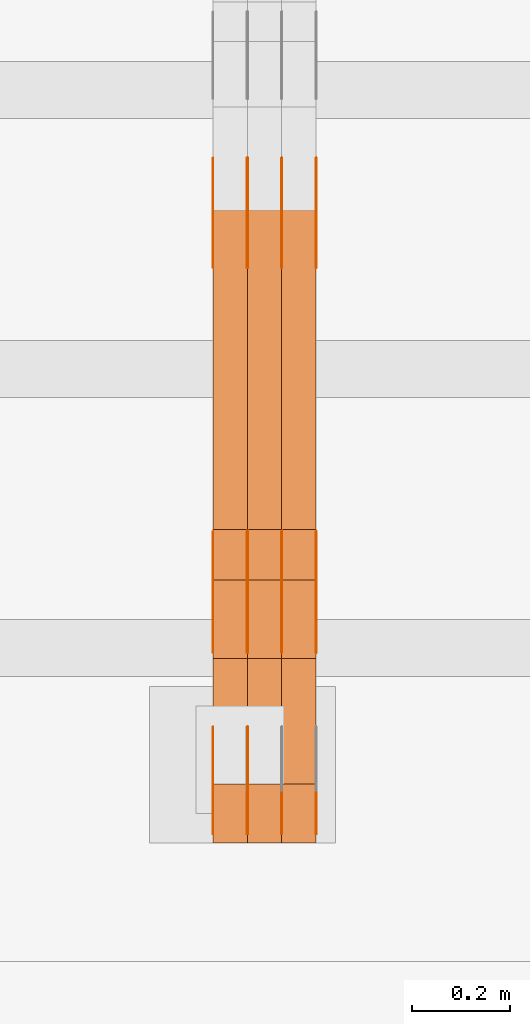
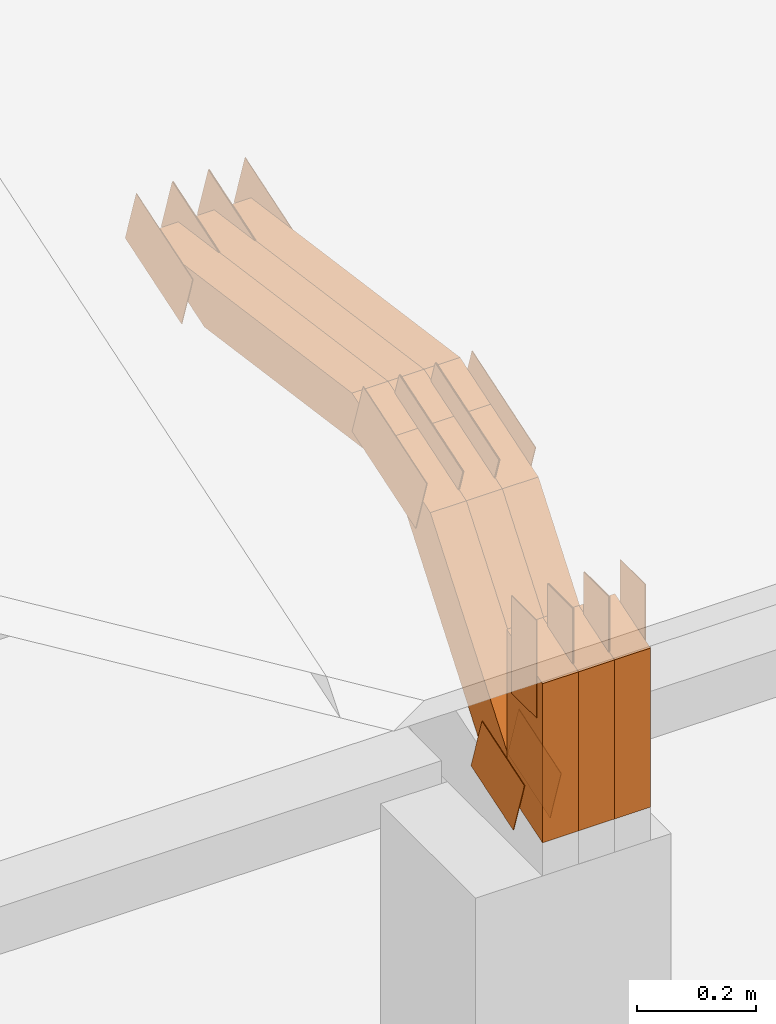
# One storey, part 57 of 385: 29 proxies.
"""IFC2X3 building model written with IfcOpenShell, lengths in millimetres."""

from ifc_helpers import new_model, entity, si_unit, converted_unit, derived_unit, direction, frame, frame_2d, origin, place, context, subcontext, project, spatial, polyline, rectangle, outline, extrude, source, transform, mapped, material, type_object, type_shapes, element, save


model = new_model("IFC2X3")

# Units and contexts
model_context = context("Model", 3, precision=0.01, world=origin(), true_north=direction((6.12303176911189e-17, 1.0)))
body_context = subcontext(model_context, "Body", "Model", "MODEL_VIEW")
ifc_project = project(units=[si_unit("LENGTHUNIT", "METRE", prefix="MILLI"), si_unit("AREAUNIT", "SQUARE_METRE"), si_unit("VOLUMEUNIT", "CUBIC_METRE"), converted_unit("PLANEANGLEUNIT", "DEGREE", entity("IfcRatioMeasure", 0.0174532925199433), si_unit("PLANEANGLEUNIT", "RADIAN"), dimensions=[0, 0, 0, 0, 0, 0, 0]), si_unit("MASSUNIT", "GRAM", prefix="KILO"), derived_unit("MASSDENSITYUNIT", [(si_unit("MASSUNIT", "GRAM", prefix="KILO"), 1), (si_unit("LENGTHUNIT", "METRE"), -3)]), si_unit("TIMEUNIT", "SECOND"), si_unit("FREQUENCYUNIT", "HERTZ"), si_unit("THERMODYNAMICTEMPERATUREUNIT", "DEGREE_CELSIUS"), derived_unit("THERMALTRANSMITTANCEUNIT", [(si_unit("MASSUNIT", "GRAM", prefix="KILO"), 1), (si_unit("THERMODYNAMICTEMPERATUREUNIT", "KELVIN"), -1), (si_unit("TIMEUNIT", "SECOND"), -3)]), derived_unit("VOLUMETRICFLOWRATEUNIT", [(si_unit("LENGTHUNIT", "METRE"), 3), (si_unit("TIMEUNIT", "SECOND"), -1)]), si_unit("ELECTRICCURRENTUNIT", "AMPERE"), si_unit("ELECTRICVOLTAGEUNIT", "VOLT"), si_unit("POWERUNIT", "WATT"), si_unit("FORCEUNIT", "NEWTON", prefix="KILO"), si_unit("ILLUMINANCEUNIT", "LUX"), si_unit("LUMINOUSFLUXUNIT", "LUMEN"), si_unit("LUMINOUSINTENSITYUNIT", "CANDELA"), derived_unit("USERDEFINED", [(si_unit("MASSUNIT", "GRAM", prefix="KILO"), -1), (si_unit("LENGTHUNIT", "METRE"), -2), (si_unit("TIMEUNIT", "SECOND"), 3), (si_unit("LUMINOUSFLUXUNIT", "LUMEN"), 1)]), derived_unit("LINEARVELOCITYUNIT", [(si_unit("LENGTHUNIT", "METRE"), 1), (si_unit("TIMEUNIT", "SECOND"), -1)]), si_unit("PRESSUREUNIT", "PASCAL"), derived_unit("USERDEFINED", [(si_unit("LENGTHUNIT", "METRE"), -2), (si_unit("MASSUNIT", "GRAM", prefix="KILO"), 1), (si_unit("TIMEUNIT", "SECOND"), -2)])], contexts=[model_context])

# Site, building, storey
site_placement = place(None, origin())
site = spatial("IfcSite", under=ifc_project, at=site_placement, CompositionType="ELEMENT")
building_placement = place(site_placement, origin())
building = spatial("IfcBuilding", under=site, at=building_placement, CompositionType="ELEMENT")
storey_placement = place(building_placement, origin())
storey = spatial("IfcBuildingStorey", under=building, at=storey_placement, Name="Default", CompositionType="ELEMENT", Elevation=0.0)

# Proxies
ifc_material_1 = material(Name="IfcSurfaceStyle #167640")
building_element_proxy_type_1 = type_object("IfcBuildingElementProxyType", PredefinedType="NOTDEFINED", material=ifc_material_1)
shared_shape_1 = source(origin(), body_context, "Body", "SweptSolid", [
    extrude(outline(polyline([(-74.999865408764, -60.0000379172698), (74.9998729365771, -60.0000379172698), (74.9998642299588, 60.0000379172698), (-74.9998717577719, 60.0000379172698), (-74.999865408764, -60.0000379172698)])), frame((75.0005044383734, 60.0001679035349, 0.0), z_axis=(0.0, 0.0, 1.0), x_axis=(-1.0, 0.0, 0.0)), (0.0, 0.0, 1.0), 1.29999999999999),
])
type_shapes(building_element_proxy_type_1, [shared_shape_1])
proxy_1_placement = place(building_placement, frame((12246.3, 2998.66143710397, 150.423871180894), z_axis=(-1.0, 0.0, 0.0), x_axis=(0.0, 0.951056516295124, 0.309016994375039)))
element("IfcBuildingElementProxy", 1, at=proxy_1_placement, inside=storey, type_object=building_element_proxy_type_1, material=ifc_material_1, context=body_context, shape_type="MappedRepresentation", body=[
    mapped(shared_shape_1, transform((0.0, 0.0, 0.0), scale=1.0)),
])
ifc_material_2 = material(Name="IfcSurfaceStyle #167583")
building_element_proxy_type_2 = type_object("IfcBuildingElementProxyType", PredefinedType="NOTDEFINED", material=ifc_material_2)
shared_shape_2 = source(origin(), body_context, "Body", "SweptSolid", [
    extrude(outline(polyline([(-74.999865408764, -60.0000379172698), (74.9998729365771, -60.0000379172698), (74.9998642299588, 60.0000379172698), (-74.9998717577719, 60.0000379172698), (-74.999865408764, -60.0000379172698)])), frame((75.0005044383734, 60.0001679035349, 0.0), z_axis=(0.0, 0.0, 1.0), x_axis=(-1.0, 0.0, 0.0)), (0.0, 0.0, 1.0), 1.29999999999999),
])
type_shapes(building_element_proxy_type_2, [shared_shape_2])
proxy_2_placement = place(building_placement, frame((12175.0, 2998.66143710397, 150.423871180894), z_axis=(-1.0, 0.0, 0.0), x_axis=(0.0, 0.951056516295124, 0.309016994375039)))
element("IfcBuildingElementProxy", 2, at=proxy_2_placement, inside=storey, type_object=building_element_proxy_type_2, material=ifc_material_2, context=body_context, shape_type="MappedRepresentation", body=[
    mapped(shared_shape_2, transform((0.0, 0.0, 0.0), scale=1.0)),
])
ifc_material_3 = material(Name="IfcSurfaceStyle #167526")
building_element_proxy_type_3 = type_object("IfcBuildingElementProxyType", PredefinedType="NOTDEFINED", material=ifc_material_3)
shared_shape_3 = source(origin(), body_context, "Body", "SweptSolid", [
    extrude(outline(polyline([(-99.9998204243802, -60.000067376167), (99.9998338462265, -60.000067376167), (99.9998204243802, 60.000067376167), (-99.9998338462265, 60.000067376167), (-99.9998204243802, -60.000067376167)])), frame((100.000602015329, 60.0001864986889, 0.0), z_axis=(0.0, 0.0, 1.0), x_axis=(-1.0, 0.0, 0.0)), (0.0, 0.0, 1.0), 1.3),
])
type_shapes(building_element_proxy_type_3, [shared_shape_3])
proxy_3_placement = place(building_placement, frame((12386.3, 4114.85465165112, 513.097031388771), z_axis=(-1.0, 0.0, 0.0), x_axis=(0.0, 0.951056516295124, 0.309016994375039)))
element("IfcBuildingElementProxy", 3, at=proxy_3_placement, inside=storey, type_object=building_element_proxy_type_3, material=ifc_material_3, context=body_context, shape_type="MappedRepresentation", body=[
    mapped(shared_shape_3, transform((0.0, 0.0, 0.0), scale=1.0)),
])
ifc_material_4 = material(Name="IfcSurfaceStyle #167469")
building_element_proxy_type_4 = type_object("IfcBuildingElementProxyType", PredefinedType="NOTDEFINED", material=ifc_material_4)
shared_shape_4 = source(origin(), body_context, "Body", "SweptSolid", [
    extrude(outline(polyline([(-99.9998204243802, -60.000067376167), (99.9998338462265, -60.000067376167), (99.9998204243802, 60.000067376167), (-99.9998338462265, 60.000067376167), (-99.9998204243802, -60.000067376167)])), frame((100.000602015329, 60.0001864986889, 0.0), z_axis=(0.0, 0.0, 1.0), x_axis=(-1.0, 0.0, 0.0)), (0.0, 0.0, 1.0), 1.3),
])
type_shapes(building_element_proxy_type_4, [shared_shape_4])
proxy_4_placement = place(building_placement, frame((12315.0, 4114.85465165112, 513.097031388771), z_axis=(-1.0, 0.0, 0.0), x_axis=(0.0, 0.951056516295124, 0.309016994375039)))
element("IfcBuildingElementProxy", 4, at=proxy_4_placement, inside=storey, type_object=building_element_proxy_type_4, material=ifc_material_4, context=body_context, shape_type="MappedRepresentation", body=[
    mapped(shared_shape_4, transform((0.0, 0.0, 0.0), scale=1.0)),
])
ifc_material_5 = material(Name="IfcSurfaceStyle #167412")
building_element_proxy_type_5 = type_object("IfcBuildingElementProxyType", PredefinedType="NOTDEFINED", material=ifc_material_5)
shared_shape_5 = source(origin(), body_context, "Body", "SweptSolid", [
    extrude(outline(polyline([(-99.9998204243802, -60.000067376167), (99.9998338462265, -60.000067376167), (99.9998204243802, 60.000067376167), (-99.9998338462265, 60.000067376167), (-99.9998204243802, -60.000067376167)])), frame((100.000602015329, 60.0001864986889, 0.0), z_axis=(0.0, 0.0, 1.0), x_axis=(-1.0, 0.0, 0.0)), (0.0, 0.0, 1.0), 1.3),
])
type_shapes(building_element_proxy_type_5, [shared_shape_5])
proxy_5_placement = place(building_placement, frame((12316.3, 4114.85465165112, 513.097031388771), z_axis=(-1.0, 0.0, 0.0), x_axis=(0.0, 0.951056516295124, 0.309016994375039)))
element("IfcBuildingElementProxy", 5, at=proxy_5_placement, inside=storey, type_object=building_element_proxy_type_5, material=ifc_material_5, context=body_context, shape_type="MappedRepresentation", body=[
    mapped(shared_shape_5, transform((0.0, 0.0, 0.0), scale=1.0)),
])
ifc_material_6 = material(Name="IfcSurfaceStyle #167355")
building_element_proxy_type_6 = type_object("IfcBuildingElementProxyType", PredefinedType="NOTDEFINED", material=ifc_material_6)
shared_shape_6 = source(origin(), body_context, "Body", "SweptSolid", [
    extrude(outline(polyline([(-99.9998204243802, -60.000067376167), (99.9998338462265, -60.000067376167), (99.9998204243802, 60.000067376167), (-99.9998338462265, 60.000067376167), (-99.9998204243802, -60.000067376167)])), frame((100.000602015329, 60.0001864986889, 0.0), z_axis=(0.0, 0.0, 1.0), x_axis=(-1.0, 0.0, 0.0)), (0.0, 0.0, 1.0), 1.29999999999998),
])
type_shapes(building_element_proxy_type_6, [shared_shape_6])
proxy_6_placement = place(building_placement, frame((12245.0, 4114.85465165112, 513.097031388771), z_axis=(-1.0, 0.0, 0.0), x_axis=(0.0, 0.951056516295124, 0.309016994375039)))
element("IfcBuildingElementProxy", 6, at=proxy_6_placement, inside=storey, type_object=building_element_proxy_type_6, material=ifc_material_6, context=body_context, shape_type="MappedRepresentation", body=[
    mapped(shared_shape_6, transform((0.0, 0.0, 0.0), scale=1.0)),
])
ifc_material_7 = material(Name="IfcSurfaceStyle #167298")
building_element_proxy_type_7 = type_object("IfcBuildingElementProxyType", PredefinedType="NOTDEFINED", material=ifc_material_7)
shared_shape_7 = source(origin(), body_context, "Body", "SweptSolid", [
    extrude(outline(polyline([(-99.9998204243802, -60.000067376167), (99.9998338462265, -60.000067376167), (99.9998204243802, 60.000067376167), (-99.9998338462265, 60.000067376167), (-99.9998204243802, -60.000067376167)])), frame((100.000602015329, 60.0001864986889, 0.0), z_axis=(0.0, 0.0, 1.0), x_axis=(-1.0, 0.0, 0.0)), (0.0, 0.0, 1.0), 1.29999999999998),
])
type_shapes(building_element_proxy_type_7, [shared_shape_7])
proxy_7_placement = place(building_placement, frame((12246.3, 4114.85465165112, 513.097031388771), z_axis=(-1.0, 0.0, 0.0), x_axis=(0.0, 0.951056516295124, 0.309016994375039)))
element("IfcBuildingElementProxy", 7, at=proxy_7_placement, inside=storey, type_object=building_element_proxy_type_7, material=ifc_material_7, context=body_context, shape_type="MappedRepresentation", body=[
    mapped(shared_shape_7, transform((0.0, 0.0, 0.0), scale=1.0)),
])
ifc_material_8 = material(Name="IfcSurfaceStyle #167241")
building_element_proxy_type_8 = type_object("IfcBuildingElementProxyType", PredefinedType="NOTDEFINED", material=ifc_material_8)
shared_shape_8 = source(origin(), body_context, "Body", "SweptSolid", [
    extrude(outline(polyline([(-99.9998204243802, -60.000067376167), (99.9998338462265, -60.000067376167), (99.9998204243802, 60.000067376167), (-99.9998338462265, 60.000067376167), (-99.9998204243802, -60.000067376167)])), frame((100.000602015329, 60.0001864986889, 0.0), z_axis=(0.0, 0.0, 1.0), x_axis=(-1.0, 0.0, 0.0)), (0.0, 0.0, 1.0), 1.29999999999999),
])
type_shapes(building_element_proxy_type_8, [shared_shape_8])
proxy_8_placement = place(building_placement, frame((12175.0, 4114.85465165112, 513.097031388771), z_axis=(-1.0, 0.0, 0.0), x_axis=(0.0, 0.951056516295124, 0.309016994375039)))
element("IfcBuildingElementProxy", 8, at=proxy_8_placement, inside=storey, type_object=building_element_proxy_type_8, material=ifc_material_8, context=body_context, shape_type="MappedRepresentation", body=[
    mapped(shared_shape_8, transform((0.0, 0.0, 0.0), scale=1.0)),
])
ifc_material_9 = material(Name="IfcSurfaceStyle #159318")
building_element_proxy_type_9 = type_object("IfcBuildingElementProxyType", PredefinedType="NOTDEFINED", material=ifc_material_9)
shared_shape_9 = source(origin(), body_context, "Body", "SweptSolid", [
    extrude(outline(polyline([(-112.500266735783, -59.9999130784581), (112.500275442392, -59.9999130784581), (112.500262020557, 59.9999130784582), (-112.500270727166, 59.9999130784581), (-112.500266735783, -59.9999130784581)])), frame((112.500275442392, 60.0001020984692, 0.0), z_axis=(0.0, 0.0, 1.0), x_axis=(-1.0, 0.0, 0.0)), (0.0, 0.0, 1.0), 1.3),
])
type_shapes(building_element_proxy_type_9, [shared_shape_9])
proxy_9_placement = place(building_placement, frame((12386.3, 3327.32420598508, 571.284602786019), z_axis=(-1.0, 0.0, 0.0), x_axis=(0.0, 0.951056516295154, 0.309016994374948)))
element("IfcBuildingElementProxy", 9, at=proxy_9_placement, inside=storey, type_object=building_element_proxy_type_9, material=ifc_material_9, context=body_context, shape_type="MappedRepresentation", body=[
    mapped(shared_shape_9, transform((0.0, 0.0, 0.0), scale=1.0)),
])
ifc_material_10 = material(Name="IfcSurfaceStyle #159261")
building_element_proxy_type_10 = type_object("IfcBuildingElementProxyType", PredefinedType="NOTDEFINED", material=ifc_material_10)
shared_shape_10 = source(origin(), body_context, "Body", "SweptSolid", [
    extrude(outline(polyline([(-112.500266735783, -59.9999130784581), (112.500275442392, -59.9999130784581), (112.500262020557, 59.9999130784582), (-112.500270727166, 59.9999130784581), (-112.500266735783, -59.9999130784581)])), frame((112.500275442392, 60.0001020984692, 0.0), z_axis=(0.0, 0.0, 1.0), x_axis=(-1.0, 0.0, 0.0)), (0.0, 0.0, 1.0), 1.3),
])
type_shapes(building_element_proxy_type_10, [shared_shape_10])
proxy_10_placement = place(building_placement, frame((12315.0, 3327.32420598508, 571.284602786019), z_axis=(-1.0, 0.0, 0.0), x_axis=(0.0, 0.951056516295154, 0.309016994374948)))
element("IfcBuildingElementProxy", 10, at=proxy_10_placement, inside=storey, type_object=building_element_proxy_type_10, material=ifc_material_10, context=body_context, shape_type="MappedRepresentation", body=[
    mapped(shared_shape_10, transform((0.0, 0.0, 0.0), scale=1.0)),
])
ifc_material_11 = material(Name="IfcSurfaceStyle #159204")
building_element_proxy_type_11 = type_object("IfcBuildingElementProxyType", PredefinedType="NOTDEFINED", material=ifc_material_11)
shared_shape_11 = source(origin(), body_context, "Body", "SweptSolid", [
    extrude(outline(polyline([(-112.500266735783, -59.9999130784581), (112.500275442392, -59.9999130784581), (112.500262020557, 59.9999130784582), (-112.500270727166, 59.9999130784581), (-112.500266735783, -59.9999130784581)])), frame((112.500275442392, 60.0001020984692, 0.0), z_axis=(0.0, 0.0, 1.0), x_axis=(-1.0, 0.0, 0.0)), (0.0, 0.0, 1.0), 1.3),
])
type_shapes(building_element_proxy_type_11, [shared_shape_11])
proxy_11_placement = place(building_placement, frame((12316.3, 3327.32420598508, 571.284602786019), z_axis=(-1.0, 0.0, 0.0), x_axis=(0.0, 0.951056516295154, 0.309016994374948)))
element("IfcBuildingElementProxy", 11, at=proxy_11_placement, inside=storey, type_object=building_element_proxy_type_11, material=ifc_material_11, context=body_context, shape_type="MappedRepresentation", body=[
    mapped(shared_shape_11, transform((0.0, 0.0, 0.0), scale=1.0)),
])
ifc_material_12 = material(Name="IfcSurfaceStyle #159147")
building_element_proxy_type_12 = type_object("IfcBuildingElementProxyType", PredefinedType="NOTDEFINED", material=ifc_material_12)
shared_shape_12 = source(origin(), body_context, "Body", "SweptSolid", [
    extrude(outline(polyline([(-112.500266735783, -59.9999130784581), (112.500275442392, -59.9999130784581), (112.500262020557, 59.9999130784582), (-112.500270727166, 59.9999130784581), (-112.500266735783, -59.9999130784581)])), frame((112.500275442392, 60.0001020984692, 0.0), z_axis=(0.0, 0.0, 1.0), x_axis=(-1.0, 0.0, 0.0)), (0.0, 0.0, 1.0), 1.29999999999998),
])
type_shapes(building_element_proxy_type_12, [shared_shape_12])
proxy_12_placement = place(building_placement, frame((12245.0, 3327.32420598508, 571.284602786019), z_axis=(-1.0, 0.0, 0.0), x_axis=(0.0, 0.951056516295154, 0.309016994374948)))
element("IfcBuildingElementProxy", 12, at=proxy_12_placement, inside=storey, type_object=building_element_proxy_type_12, material=ifc_material_12, context=body_context, shape_type="MappedRepresentation", body=[
    mapped(shared_shape_12, transform((0.0, 0.0, 0.0), scale=1.0)),
])
ifc_material_13 = material(Name="IfcSurfaceStyle #159090")
building_element_proxy_type_13 = type_object("IfcBuildingElementProxyType", PredefinedType="NOTDEFINED", material=ifc_material_13)
shared_shape_13 = source(origin(), body_context, "Body", "SweptSolid", [
    extrude(outline(polyline([(-112.500266735783, -59.9999130784581), (112.500275442392, -59.9999130784581), (112.500262020557, 59.9999130784582), (-112.500270727166, 59.9999130784581), (-112.500266735783, -59.9999130784581)])), frame((112.500275442392, 60.0001020984692, 0.0), z_axis=(0.0, 0.0, 1.0), x_axis=(-1.0, 0.0, 0.0)), (0.0, 0.0, 1.0), 1.29999999999998),
])
type_shapes(building_element_proxy_type_13, [shared_shape_13])
proxy_13_placement = place(building_placement, frame((12246.3, 3327.32420598508, 571.284602786019), z_axis=(-1.0, 0.0, 0.0), x_axis=(0.0, 0.951056516295154, 0.309016994374948)))
element("IfcBuildingElementProxy", 13, at=proxy_13_placement, inside=storey, type_object=building_element_proxy_type_13, material=ifc_material_13, context=body_context, shape_type="MappedRepresentation", body=[
    mapped(shared_shape_13, transform((0.0, 0.0, 0.0), scale=1.0)),
])
ifc_material_14 = material(Name="IfcSurfaceStyle #159033")
building_element_proxy_type_14 = type_object("IfcBuildingElementProxyType", PredefinedType="NOTDEFINED", material=ifc_material_14)
shared_shape_14 = source(origin(), body_context, "Body", "SweptSolid", [
    extrude(outline(polyline([(-112.500266735783, -59.9999130784581), (112.500275442392, -59.9999130784581), (112.500262020557, 59.9999130784582), (-112.500270727166, 59.9999130784581), (-112.500266735783, -59.9999130784581)])), frame((112.500275442392, 60.0001020984692, 0.0), z_axis=(0.0, 0.0, 1.0), x_axis=(-1.0, 0.0, 0.0)), (0.0, 0.0, 1.0), 1.29999999999999),
])
type_shapes(building_element_proxy_type_14, [shared_shape_14])
proxy_14_placement = place(building_placement, frame((12175.0, 3327.32420598508, 571.284602786019), z_axis=(-1.0, 0.0, 0.0), x_axis=(0.0, 0.951056516295154, 0.309016994374948)))
element("IfcBuildingElementProxy", 14, at=proxy_14_placement, inside=storey, type_object=building_element_proxy_type_14, material=ifc_material_14, context=body_context, shape_type="MappedRepresentation", body=[
    mapped(shared_shape_14, transform((0.0, 0.0, 0.0), scale=1.0)),
])
ifc_material_15 = material(Name="IfcSurfaceStyle #158292")
building_element_proxy_type_15 = type_object("IfcBuildingElementProxyType", PredefinedType="NOTDEFINED", material=ifc_material_15)
shared_shape_15 = source(origin(), body_context, "Body", "SweptSolid", [
    extrude(rectangle(XDim=199.999969482422, YDim=84.0, at=frame_2d((1.4210854715202e-14, 0.0), x_axis=(1.0, 0.0))), frame((100.000010815955, 42.0, 0.0), z_axis=(0.0, 0.0, 1.0), x_axis=(-1.0, 0.0, 0.0)), (0.0, 0.0, 1.0), 1.3),
])
type_shapes(building_element_proxy_type_15, [shared_shape_15])
proxy_15_placement = place(building_placement, frame((12386.3, 3042.0, 514.460048047401), z_axis=(-1.0, 0.0, 0.0), x_axis=(0.0, 0.0, -1.0)))
element("IfcBuildingElementProxy", 15, at=proxy_15_placement, inside=storey, type_object=building_element_proxy_type_15, material=ifc_material_15, context=body_context, shape_type="MappedRepresentation", body=[
    mapped(shared_shape_15, transform((0.0, 0.0, 0.0), scale=1.0)),
])
ifc_material_16 = material(Name="IfcSurfaceStyle #158235")
building_element_proxy_type_16 = type_object("IfcBuildingElementProxyType", PredefinedType="NOTDEFINED", material=ifc_material_16)
shared_shape_16 = source(origin(), body_context, "Body", "SweptSolid", [
    extrude(rectangle(XDim=199.999969482422, YDim=84.0, at=frame_2d((1.4210854715202e-14, 0.0), x_axis=(1.0, 0.0))), frame((100.000010815955, 42.0, 0.0), z_axis=(0.0, 0.0, 1.0), x_axis=(-1.0, 0.0, 0.0)), (0.0, 0.0, 1.0), 1.3),
])
type_shapes(building_element_proxy_type_16, [shared_shape_16])
proxy_16_placement = place(building_placement, frame((12315.0, 3042.0, 514.460048047401), z_axis=(-1.0, 0.0, 0.0), x_axis=(0.0, 0.0, -1.0)))
element("IfcBuildingElementProxy", 16, at=proxy_16_placement, inside=storey, type_object=building_element_proxy_type_16, material=ifc_material_16, context=body_context, shape_type="MappedRepresentation", body=[
    mapped(shared_shape_16, transform((0.0, 0.0, 0.0), scale=1.0)),
])
ifc_material_17 = material(Name="IfcSurfaceStyle #158178")
building_element_proxy_type_17 = type_object("IfcBuildingElementProxyType", PredefinedType="NOTDEFINED", material=ifc_material_17)
shared_shape_17 = source(origin(), body_context, "Body", "SweptSolid", [
    extrude(rectangle(XDim=199.999969482422, YDim=84.0, at=frame_2d((1.4210854715202e-14, 0.0), x_axis=(1.0, 0.0))), frame((100.000010815955, 42.0, 0.0), z_axis=(0.0, 0.0, 1.0), x_axis=(-1.0, 0.0, 0.0)), (0.0, 0.0, 1.0), 1.3),
])
type_shapes(building_element_proxy_type_17, [shared_shape_17])
proxy_17_placement = place(building_placement, frame((12316.3, 3042.0, 514.460048047401), z_axis=(-1.0, 0.0, 0.0), x_axis=(0.0, 0.0, -1.0)))
element("IfcBuildingElementProxy", 17, at=proxy_17_placement, inside=storey, type_object=building_element_proxy_type_17, material=ifc_material_17, context=body_context, shape_type="MappedRepresentation", body=[
    mapped(shared_shape_17, transform((0.0, 0.0, 0.0), scale=1.0)),
])
ifc_material_18 = material(Name="IfcSurfaceStyle #158121")
building_element_proxy_type_18 = type_object("IfcBuildingElementProxyType", PredefinedType="NOTDEFINED", material=ifc_material_18)
shared_shape_18 = source(origin(), body_context, "Body", "SweptSolid", [
    extrude(rectangle(XDim=199.999969482422, YDim=84.0, at=frame_2d((1.4210854715202e-14, 0.0), x_axis=(1.0, 0.0))), frame((100.000010815955, 42.0, 0.0), z_axis=(0.0, 0.0, 1.0), x_axis=(-1.0, 0.0, 0.0)), (0.0, 0.0, 1.0), 1.29999999999998),
])
type_shapes(building_element_proxy_type_18, [shared_shape_18])
proxy_18_placement = place(building_placement, frame((12245.0, 3042.0, 514.460048047401), z_axis=(-1.0, 0.0, 0.0), x_axis=(0.0, 0.0, -1.0)))
element("IfcBuildingElementProxy", 18, at=proxy_18_placement, inside=storey, type_object=building_element_proxy_type_18, material=ifc_material_18, context=body_context, shape_type="MappedRepresentation", body=[
    mapped(shared_shape_18, transform((0.0, 0.0, 0.0), scale=1.0)),
])
ifc_material_19 = material(Name="IfcSurfaceStyle #158064")
building_element_proxy_type_19 = type_object("IfcBuildingElementProxyType", PredefinedType="NOTDEFINED", material=ifc_material_19)
shared_shape_19 = source(origin(), body_context, "Body", "SweptSolid", [
    extrude(rectangle(XDim=199.999969482422, YDim=84.0, at=frame_2d((1.4210854715202e-14, 0.0), x_axis=(1.0, 0.0))), frame((100.000010815955, 42.0, 0.0), z_axis=(0.0, 0.0, 1.0), x_axis=(-1.0, 0.0, 0.0)), (0.0, 0.0, 1.0), 1.29999999999998),
])
type_shapes(building_element_proxy_type_19, [shared_shape_19])
proxy_19_placement = place(building_placement, frame((12246.3, 3042.0, 514.460048047401), z_axis=(-1.0, 0.0, 0.0), x_axis=(0.0, 0.0, -1.0)))
element("IfcBuildingElementProxy", 19, at=proxy_19_placement, inside=storey, type_object=building_element_proxy_type_19, material=ifc_material_19, context=body_context, shape_type="MappedRepresentation", body=[
    mapped(shared_shape_19, transform((0.0, 0.0, 0.0), scale=1.0)),
])
ifc_material_20 = material(Name="IfcSurfaceStyle #158007")
building_element_proxy_type_20 = type_object("IfcBuildingElementProxyType", PredefinedType="NOTDEFINED", material=ifc_material_20)
shared_shape_20 = source(origin(), body_context, "Body", "SweptSolid", [
    extrude(rectangle(XDim=199.999969482422, YDim=84.0, at=frame_2d((1.4210854715202e-14, 0.0), x_axis=(1.0, 0.0))), frame((100.000010815955, 42.0, 0.0), z_axis=(0.0, 0.0, 1.0), x_axis=(-1.0, 0.0, 0.0)), (0.0, 0.0, 1.0), 1.29999999999999),
])
type_shapes(building_element_proxy_type_20, [shared_shape_20])
proxy_20_placement = place(building_placement, frame((12175.0, 3042.0, 514.460048047401), z_axis=(-1.0, 0.0, 0.0), x_axis=(0.0, 0.0, -1.0)))
element("IfcBuildingElementProxy", 20, at=proxy_20_placement, inside=storey, type_object=building_element_proxy_type_20, material=ifc_material_20, context=body_context, shape_type="MappedRepresentation", body=[
    mapped(shared_shape_20, transform((0.0, 0.0, 0.0), scale=1.0)),
])
ifc_material_21 = material(Name="IfcSurfaceStyle #147024")
building_element_proxy_type_21 = type_object("IfcBuildingElementProxyType", Name="T1-W3 147022", PredefinedType="NOTDEFINED", material=ifc_material_21)
shared_shape_21 = source(origin(), body_context, "Body", "SweptSolid", [
    extrude(outline(polyline([(-314.232579911788, -47.5000200125938), (325.164873061766, -47.5000200125938), (297.999869081008, 6.48085173424295e-05), (200.434027234171, 47.4999876083351), (-509.366189465157, 47.4999876083352), (-314.232579911788, -47.5000200125938)])), frame((325.164873061766, 47.5001564752191, 0.0), z_axis=(0.0, 0.0, 1.0), x_axis=(-1.0, 0.0, 0.0)), (0.0, 0.0, 1.0), 70.0),
])
type_shapes(building_element_proxy_type_21, [shared_shape_21])
proxy_21_placement = place(building_placement, frame((12385.0, 3457.43747924875, 620.49890325051), z_axis=(-1.0, 0.0, 0.0), x_axis=(0.0, 0.990367219823621, -0.138465771578512)))
element("IfcBuildingElementProxy", 21, at=proxy_21_placement, inside=storey, type_object=building_element_proxy_type_21, material=ifc_material_21, Name="T1-W3", context=body_context, shape_type="MappedRepresentation", body=[
    mapped(shared_shape_21, transform((0.0, 0.0, 0.0), scale=1.0)),
])
ifc_material_22 = material(Name="IfcSurfaceStyle #146958")
building_element_proxy_type_22 = type_object("IfcBuildingElementProxyType", Name="T1-W3 146956", PredefinedType="NOTDEFINED", material=ifc_material_22)
shared_shape_22 = source(origin(), body_context, "Body", "SweptSolid", [
    extrude(outline(polyline([(-314.232579911788, -47.5000200125938), (325.164873061766, -47.5000200125938), (297.999869081008, 6.48085173424295e-05), (200.434027234171, 47.4999876083351), (-509.366189465157, 47.4999876083352), (-314.232579911788, -47.5000200125938)])), frame((325.164873061766, 47.5001564752191, 0.0), z_axis=(0.0, 0.0, 1.0), x_axis=(-1.0, 0.0, 0.0)), (0.0, 0.0, 1.0), 70.0),
])
type_shapes(building_element_proxy_type_22, [shared_shape_22])
proxy_22_placement = place(building_placement, frame((12315.0, 3457.43747924875, 620.49890325051), z_axis=(-1.0, 0.0, 0.0), x_axis=(0.0, 0.990367219823621, -0.138465771578512)))
element("IfcBuildingElementProxy", 22, at=proxy_22_placement, inside=storey, type_object=building_element_proxy_type_22, material=ifc_material_22, Name="T1-W3", context=body_context, shape_type="MappedRepresentation", body=[
    mapped(shared_shape_22, transform((0.0, 0.0, 0.0), scale=1.0)),
])
ifc_material_23 = material(Name="IfcSurfaceStyle #146892")
building_element_proxy_type_23 = type_object("IfcBuildingElementProxyType", Name="T1-W3 146890", PredefinedType="NOTDEFINED", material=ifc_material_23)
shared_shape_23 = source(origin(), body_context, "Body", "SweptSolid", [
    extrude(outline(polyline([(-314.232579911788, -47.5000200125938), (325.164873061766, -47.5000200125938), (297.999869081008, 6.48085173424295e-05), (200.434027234171, 47.4999876083351), (-509.366189465157, 47.4999876083352), (-314.232579911788, -47.5000200125938)])), frame((325.164873061766, 47.5001564752191, 0.0), z_axis=(0.0, 0.0, 1.0), x_axis=(-1.0, 0.0, 0.0)), (0.0, 0.0, 1.0), 70.0),
])
type_shapes(building_element_proxy_type_23, [shared_shape_23])
proxy_23_placement = place(building_placement, frame((12245.0, 3457.43747924875, 620.49890325051), z_axis=(-1.0, 0.0, 0.0), x_axis=(0.0, 0.990367219823621, -0.138465771578512)))
element("IfcBuildingElementProxy", 23, at=proxy_23_placement, inside=storey, type_object=building_element_proxy_type_23, material=ifc_material_23, Name="T1-W3", context=body_context, shape_type="MappedRepresentation", body=[
    mapped(shared_shape_23, transform((0.0, 0.0, 0.0), scale=1.0)),
])
ifc_material_24 = material(Name="IfcSurfaceStyle #146628")
building_element_proxy_type_24 = type_object("IfcBuildingElementProxyType", Name="T1-W14 146626", PredefinedType="NOTDEFINED", material=ifc_material_24)
shared_shape_24 = source(origin(), body_context, "Body", "SweptSolid", [
    extrude(outline(polyline([(-374.484689776928, -47.499919737532), (177.199556189275, -47.499919737532), (246.893257937645, -5.36774925340877e-05), (185.487930694801, 47.4999465762783), (-235.096055044793, 47.4999465762784), (-374.484689776928, -47.499919737532)])), frame((246.893257937645, 47.5000959779252, 0.0), z_axis=(0.0, 0.0, 1.0), x_axis=(-1.0, 0.0, 0.0)), (0.0, 0.0, 1.0), 70.0),
])
type_shapes(building_element_proxy_type_24, [shared_shape_24])
proxy_24_placement = place(building_placement, frame((12385.0, 3022.42877773024, 136.329406512195), z_axis=(-1.0, 0.0, 0.0), x_axis=(0.0, 0.611854146609475, 0.790970608352037)))
element("IfcBuildingElementProxy", 24, at=proxy_24_placement, inside=storey, type_object=building_element_proxy_type_24, material=ifc_material_24, Name="T1-W14", context=body_context, shape_type="MappedRepresentation", body=[
    mapped(shared_shape_24, transform((0.0, 0.0, 0.0), scale=1.0)),
])
ifc_material_25 = material(Name="IfcSurfaceStyle #146562")
building_element_proxy_type_25 = type_object("IfcBuildingElementProxyType", Name="T1-W14 146560", PredefinedType="NOTDEFINED", material=ifc_material_25)
shared_shape_25 = source(origin(), body_context, "Body", "SweptSolid", [
    extrude(outline(polyline([(-374.484689776928, -47.499919737532), (177.199556189275, -47.499919737532), (246.893257937645, -5.36774925340877e-05), (185.487930694801, 47.4999465762783), (-235.096055044793, 47.4999465762784), (-374.484689776928, -47.499919737532)])), frame((246.893257937645, 47.5000959779252, 0.0), z_axis=(0.0, 0.0, 1.0), x_axis=(-1.0, 0.0, 0.0)), (0.0, 0.0, 1.0), 70.0),
])
type_shapes(building_element_proxy_type_25, [shared_shape_25])
proxy_25_placement = place(building_placement, frame((12315.0, 3022.42877773024, 136.329406512195), z_axis=(-1.0, 0.0, 0.0), x_axis=(0.0, 0.611854146609475, 0.790970608352037)))
element("IfcBuildingElementProxy", 25, at=proxy_25_placement, inside=storey, type_object=building_element_proxy_type_25, material=ifc_material_25, Name="T1-W14", context=body_context, shape_type="MappedRepresentation", body=[
    mapped(shared_shape_25, transform((0.0, 0.0, 0.0), scale=1.0)),
])
ifc_material_26 = material(Name="IfcSurfaceStyle #146496")
building_element_proxy_type_26 = type_object("IfcBuildingElementProxyType", Name="T1-W14 146494", PredefinedType="NOTDEFINED", material=ifc_material_26)
shared_shape_26 = source(origin(), body_context, "Body", "SweptSolid", [
    extrude(outline(polyline([(-374.484689776928, -47.499919737532), (177.199556189275, -47.499919737532), (246.893257937645, -5.36774925340877e-05), (185.487930694801, 47.4999465762783), (-235.096055044793, 47.4999465762784), (-374.484689776928, -47.499919737532)])), frame((246.893257937645, 47.5000959779252, 0.0), z_axis=(0.0, 0.0, 1.0), x_axis=(-1.0, 0.0, 0.0)), (0.0, 0.0, 1.0), 70.0),
])
type_shapes(building_element_proxy_type_26, [shared_shape_26])
proxy_26_placement = place(building_placement, frame((12245.0, 3022.42877773024, 136.329406512195), z_axis=(-1.0, 0.0, 0.0), x_axis=(0.0, 0.611854146609475, 0.790970608352037)))
element("IfcBuildingElementProxy", 26, at=proxy_26_placement, inside=storey, type_object=building_element_proxy_type_26, material=ifc_material_26, Name="T1-W14", context=body_context, shape_type="MappedRepresentation", body=[
    mapped(shared_shape_26, transform((0.0, 0.0, 0.0), scale=1.0)),
])
ifc_material_27 = material(Name="IfcSurfaceStyle #146430")
building_element_proxy_type_27 = type_object("IfcBuildingElementProxyType", Name="T1-E3 146428", PredefinedType="NOTDEFINED", material=ifc_material_27)
shared_shape_27 = source(origin(), body_context, "Body", "SweptSolid", [
    extrude(outline(polyline([(-182.839673995971, -60.0), (143.849313735962, -60.0), (182.839677810669, 60.0), (-143.84931755066, 60.0), (-182.839673995971, -60.0)])), frame((182.839677810669, 60.0, 0.0), z_axis=(0.0, 0.0, 1.0), x_axis=(-1.0, 0.0, 0.0)), (0.0, 0.0, 1.0), 70.0),
])
type_shapes(building_element_proxy_type_27, [shared_shape_27])
proxy_27_placement = place(building_placement, frame((12385.0, 2940.0, 68.27587890625), z_axis=(-1.0, 0.0, 0.0), x_axis=(0.0, 0.0, 1.0)))
element("IfcBuildingElementProxy", 27, at=proxy_27_placement, inside=storey, type_object=building_element_proxy_type_27, material=ifc_material_27, Name="T1-E3", context=body_context, shape_type="MappedRepresentation", body=[
    mapped(shared_shape_27, transform((0.0, 0.0, 0.0), scale=1.0)),
])
ifc_material_28 = material(Name="IfcSurfaceStyle #146373")
building_element_proxy_type_28 = type_object("IfcBuildingElementProxyType", Name="T1-E3 146371", PredefinedType="NOTDEFINED", material=ifc_material_28)
shared_shape_28 = source(origin(), body_context, "Body", "SweptSolid", [
    extrude(outline(polyline([(-182.839673995971, -60.0), (143.849313735962, -60.0), (182.839677810669, 60.0), (-143.84931755066, 60.0), (-182.839673995971, -60.0)])), frame((182.839677810669, 60.0, 0.0), z_axis=(0.0, 0.0, 1.0), x_axis=(-1.0, 0.0, 0.0)), (0.0, 0.0, 1.0), 70.0),
])
type_shapes(building_element_proxy_type_28, [shared_shape_28])
proxy_28_placement = place(building_placement, frame((12315.0, 2940.0, 68.27587890625), z_axis=(-1.0, 0.0, 0.0), x_axis=(0.0, 0.0, 1.0)))
element("IfcBuildingElementProxy", 28, at=proxy_28_placement, inside=storey, type_object=building_element_proxy_type_28, material=ifc_material_28, Name="T1-E3", context=body_context, shape_type="MappedRepresentation", body=[
    mapped(shared_shape_28, transform((0.0, 0.0, 0.0), scale=1.0)),
])
ifc_material_29 = material(Name="IfcSurfaceStyle #146316")
building_element_proxy_type_29 = type_object("IfcBuildingElementProxyType", Name="T1-E3 146314", PredefinedType="NOTDEFINED", material=ifc_material_29)
shared_shape_29 = source(origin(), body_context, "Body", "SweptSolid", [
    extrude(outline(polyline([(-182.839673995971, -60.0), (143.849313735962, -60.0), (182.839677810669, 60.0), (-143.84931755066, 60.0), (-182.839673995971, -60.0)])), frame((182.839677810669, 60.0, 0.0), z_axis=(0.0, 0.0, 1.0), x_axis=(-1.0, 0.0, 0.0)), (0.0, 0.0, 1.0), 70.0),
])
type_shapes(building_element_proxy_type_29, [shared_shape_29])
proxy_29_placement = place(building_placement, frame((12245.0, 2940.0, 68.27587890625), z_axis=(-1.0, 0.0, 0.0), x_axis=(0.0, 0.0, 1.0)))
element("IfcBuildingElementProxy", 29, at=proxy_29_placement, inside=storey, type_object=building_element_proxy_type_29, material=ifc_material_29, Name="T1-E3", context=body_context, shape_type="MappedRepresentation", body=[
    mapped(shared_shape_29, transform((0.0, 0.0, 0.0), scale=1.0)),
])

save(model, "model.ifc")
